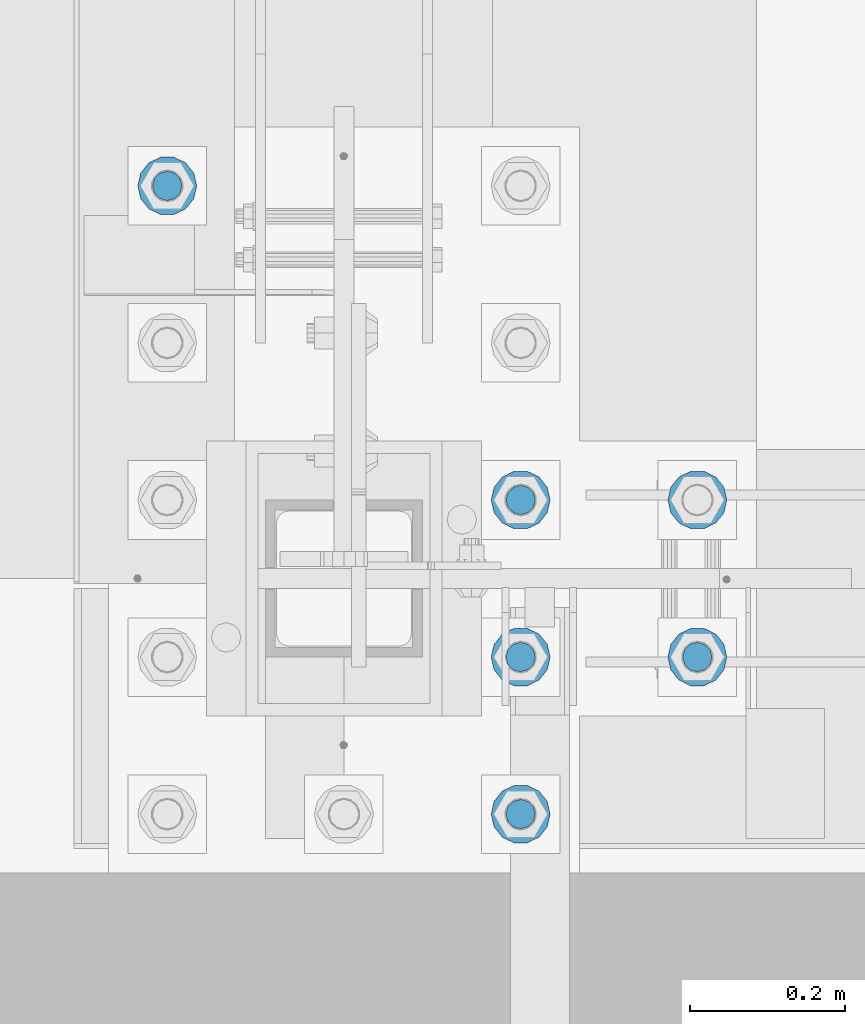
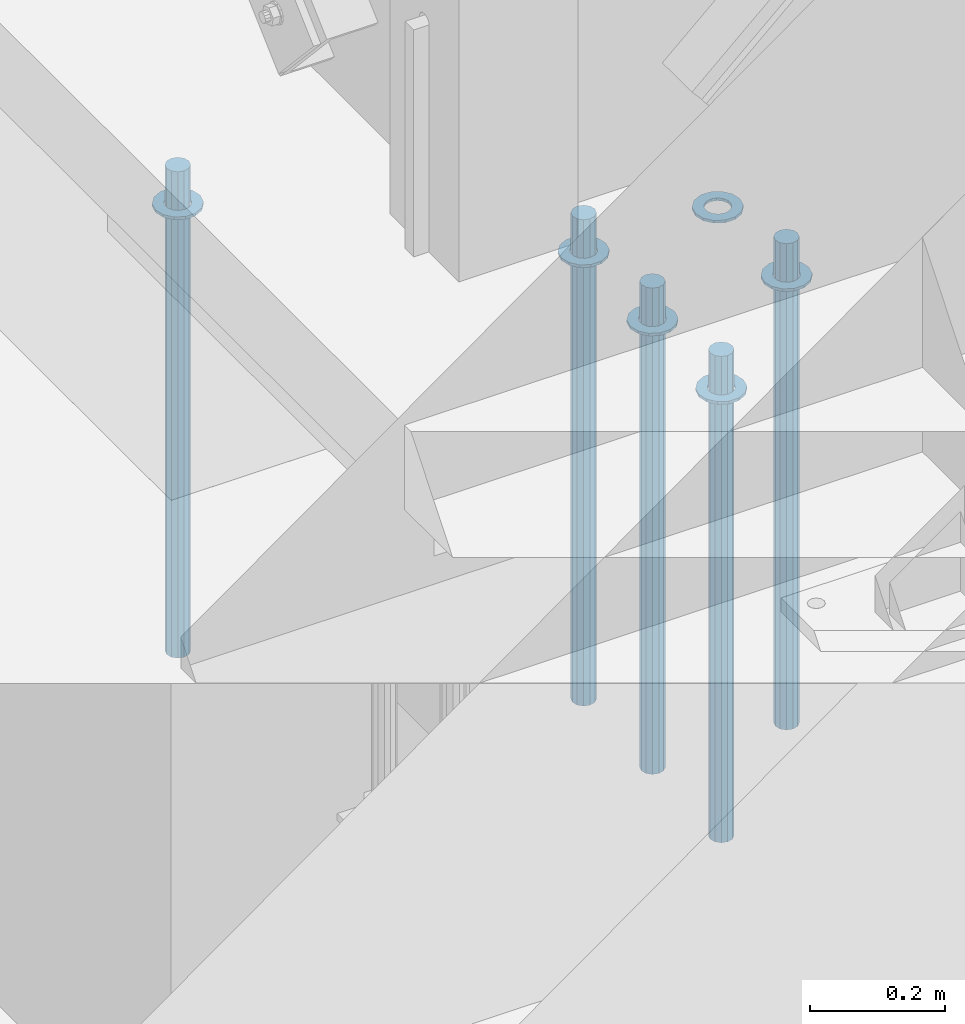
# One storey, part 919 of 1763: 11 columns, 1 element without a shape of its own.
"""IFC2X3 building model written with IfcOpenShell, lengths in millimetres."""

import ifcopenshell
import ifcopenshell.guid

model = None  # the IFC model being written
_history = None  # IfcOwnerHistory: only IFC2X3 demands one
_inside = {}  # id of a spatial element -> (the spatial element, [elements in it])
_under = {}  # id of a project, library or spatial element -> (it, [spatial elements below it])
_declared = {}  # id of a project -> (the project, [libraries it declares])
_typed = {}  # id of a type object -> (the type object, [elements of that type])
_made_of = {}  # id of a material, layer set ... -> (it, [elements and type objects made of it])


def new_model(schema):
    """Start an empty IFC model of exactly this schema.

    Asked for "IFC4X3", IfcOpenShell would pick the latest addendum, in which some entities
    have other attributes; the version numbers below select the first issue.
    IFC2X3 requires an IfcOwnerHistory on every rooted entity: one is made here for all.
    """
    global model, _history
    if schema == "IFC4X3":
        model = ifcopenshell.file(schema_version=(4, 3, 0, 0))
    else:
        model = ifcopenshell.file(schema=schema)
    _inside.clear()
    _under.clear()
    _declared.clear()
    _typed.clear()
    _made_of.clear()
    _history = None
    if model.schema == "IFC2X3":
        org = make("IfcOrganization", Name="unknown")
        user = make(
            "IfcPersonAndOrganization",
            ThePerson=make("IfcPerson", FamilyName="unknown"),
            TheOrganization=org,
        )
        app = make(
            "IfcApplication",
            ApplicationDeveloper=org,
            Version="unknown",
            ApplicationFullName="unknown",
            ApplicationIdentifier="unknown",
        )
        _history = make(
            "IfcOwnerHistory",
            OwningUser=user,
            OwningApplication=app,
            ChangeAction="ADDED",
            CreationDate=0,
        )
    return model


def make(cls, **values):
    """One entity of the class cls with the attributes given. An attribute that is None is left unset."""
    return model.create_entity(
        cls, **{name: value for name, value in values.items() if value is not None}
    )


def rooted(cls, **values):
    """An entity with a GlobalId (a new one), such as an element, a storey or a relation."""
    return make(cls, GlobalId=ifcopenshell.guid.new(), OwnerHistory=_history, **values)


def si_unit(unit_type, name, prefix=None):
    """IfcSIUnit, for example si_unit("LENGTHUNIT", "METRE", prefix="MILLI")."""
    return make("IfcSIUnit", UnitType=unit_type, Prefix=prefix, Name=name)


def assignment(units):
    """IfcUnitAssignment: the units of a project."""
    return None if units is None else make("IfcUnitAssignment", Units=units)


def point(xyz):
    """IfcCartesianPoint."""
    return None if xyz is None else make("IfcCartesianPoint", Coordinates=xyz)


def direction(xyz):
    """IfcDirection."""
    return None if xyz is None else make("IfcDirection", DirectionRatios=xyz)


def frame(location, z_axis=None, x_axis=None):
    """IfcAxis2Placement3D, a coordinate frame: its origin and axes. An axis left out is left unset."""
    return make(
        "IfcAxis2Placement3D",
        Location=point(location),
        Axis=direction(z_axis),
        RefDirection=direction(x_axis),
    )


def origin_with_axes():
    """The frame at (0, 0, 0) with the z axis (0, 0, 1) and the x axis (1, 0, 0) written out."""
    return frame((0.0, 0.0, 0.0), z_axis=(0.0, 0.0, 1.0), x_axis=(1.0, 0.0, 0.0))


def place(relative_to, where):
    """IfcLocalPlacement: puts the frame where relative to a parent placement (None: the world)."""
    return make(
        "IfcLocalPlacement", PlacementRelTo=relative_to, RelativePlacement=where
    )


def context(
    kind, dimensions, precision=None, world=None, true_north=None, identifier=None
):
    """IfcGeometricRepresentationContext, for example the 3D "Model" context."""
    return make(
        "IfcGeometricRepresentationContext",
        ContextIdentifier=identifier,
        ContextType=kind,
        CoordinateSpaceDimension=dimensions,
        Precision=precision,
        WorldCoordinateSystem=world,
        TrueNorth=true_north,
    )


def subcontext(parent, identifier, kind, view, scale=None):
    """IfcGeometricRepresentationSubContext, for example "Body" below "Model"."""
    return make(
        "IfcGeometricRepresentationSubContext",
        ContextIdentifier=identifier,
        ContextType=kind,
        ParentContext=parent,
        TargetScale=scale,
        TargetView=view,
    )


def project(units=None, contexts=None):
    """IfcProject with its units and contexts."""
    return rooted(
        "IfcProject",
        Name="project",
        RepresentationContexts=contexts,
        UnitsInContext=assignment(units),
    )


def spatial(cls, under=None, at=None, **own):
    """A site, building, storey or space (cls), placed at a placement, below another one or the project."""
    s = rooted(cls, ObjectPlacement=at, **own)
    if under is not None:
        _under.setdefault(under.id(), (under, []))[1].append(s)
    return s


def faces_of(points, faces, orient=None, outer=None):
    """IfcFace entities. A face is a list of loops; a loop is a list of indices into points, from 0.

    orient and outer hold one flag for each loop. By default every Orientation is true, the
    first loop of a face is its IfcFaceOuterBound and the others are IfcFaceBound.
    """
    made = []
    for i, loops in enumerate(faces):
        bounds = []
        for j, loop in enumerate(loops):
            is_outer = j == 0 if outer is None else outer[i][j]
            bounds.append(
                make(
                    "IfcFaceOuterBound" if is_outer else "IfcFaceBound",
                    Bound=make("IfcPolyLoop", Polygon=[points[k] for k in loop]),
                    Orientation=True if orient is None else orient[i][j],
                )
            )
        made.append(make("IfcFace", Bounds=bounds))
    return made


def faceted_brep(points, faces, orient=None, outer=None, voids=None):
    """IfcFacetedBrep: a solid bounded by flat faces; with voids (closed shells), ...WithVoids."""
    shared = [point(p) for p in points]
    hull = make("IfcClosedShell", CfsFaces=faces_of(shared, faces, orient, outer))
    if voids is None:
        return make("IfcFacetedBrep", Outer=hull)
    return make(
        "IfcFacetedBrepWithVoids",
        Outer=hull,
        Voids=[
            make(cls, CfsFaces=faces_of(shared, fs, o, b)) for cls, fs, o, b in voids
        ],
    )


def shape(context_of_items, identifier, shape_type, items):
    """IfcShapeRepresentation: the items that make up one representation, for example the "Body"."""
    return make(
        "IfcShapeRepresentation",
        ContextOfItems=context_of_items,
        RepresentationIdentifier=identifier,
        RepresentationType=shape_type,
        Items=items,
    )


def material(Name=None, Category=None):
    """IfcMaterial."""
    return make("IfcMaterial", Name=Name, Category=Category)


def made_of(thing, what):
    """Note that an element or type object is made of a material, layer set ...; save() writes the relation."""
    if what is not None:
        _made_of.setdefault(what.id(), (what, []))[1].append(thing)
    return thing


def type_object(cls, material=None, **own):
    """A type object (cls), such as IfcWallType, which elements share."""
    return made_of(rooted(cls, **own), material)


def element(
    cls,
    number,
    at=None,
    inside=None,
    cuts=None,
    type_object=None,
    material=None,
    context=None,
    identifier="Body",
    shape_type=None,
    held_by="IfcProductDefinitionShape",
    body=None,
    shapes=None,
    **own,
):
    """One element of the class cls, such as IfcWall. Its Tag is "e" and its number.

    at: its placement. inside: the storey or other place that contains it. cuts: it is an
    opening in that element (IfcRelVoidsElement). A single representation is given by context,
    identifier, shape_type and body (its items); several are given by shapes. held_by: the class
    of the entity that holds the representations. save() writes the other relations.
    """
    e = rooted(cls, Tag="e%d" % number, ObjectPlacement=at, **own)
    if body is not None:
        shapes = [shape(context, identifier, shape_type, body)]
    if shapes is not None:
        e.Representation = make(held_by, Representations=shapes)
    if inside is not None:
        _inside.setdefault(inside.id(), (inside, []))[1].append(e)
    if cuts is not None:
        rooted(
            "IfcRelVoidsElement", RelatingBuildingElement=cuts, RelatedOpeningElement=e
        )
    if type_object is not None:
        _typed.setdefault(type_object.id(), (type_object, []))[1].append(e)
    return made_of(e, material)


def aggregate(whole, parts):
    """IfcRelAggregates: a whole, such as a stair, and the parts it consists of."""
    return rooted("IfcRelAggregates", RelatingObject=whole, RelatedObjects=parts)


def save(model, path):
    """Write the relations noted so far, then the file.

    IfcRelAggregates (storeys below a building ...), IfcRelContainedInSpatialStructure (elements
    in a storey), IfcRelDefinesByType, IfcRelAssociatesMaterial and IfcRelDeclares: one each for
    every whole, place, type object, material and project.
    """
    for whole, parts in _under.values():
        aggregate(whole, parts)
    for where, things in _inside.values():
        rooted(
            "IfcRelContainedInSpatialStructure",
            RelatedElements=things,
            RelatingStructure=where,
        )
    for kind, things in _typed.values():
        rooted("IfcRelDefinesByType", RelatedObjects=things, RelatingType=kind)
    for what, things in _made_of.values():
        rooted("IfcRelAssociatesMaterial", RelatedObjects=things, RelatingMaterial=what)
    for by, libraries in _declared.values():
        rooted("IfcRelDeclares", RelatingContext=by, RelatedDefinitions=libraries)
    model.write(path)


model = new_model("IFC2X3")

# Units and contexts
model_context = context("Model", 3, precision=1e-05, world=origin_with_axes())
body_context = subcontext(model_context, "Body", "Model", "MODEL_VIEW")
ifc_project = project(units=[si_unit("LENGTHUNIT", "METRE", prefix="MILLI"), si_unit("AREAUNIT", "SQUARE_METRE"), si_unit("VOLUMEUNIT", "CUBIC_METRE"), si_unit("MASSUNIT", "GRAM", prefix="KILO"), si_unit("TIMEUNIT", "SECOND"), si_unit("PLANEANGLEUNIT", "RADIAN"), si_unit("SOLIDANGLEUNIT", "STERADIAN"), si_unit("THERMODYNAMICTEMPERATUREUNIT", "DEGREE_CELSIUS"), si_unit("LUMINOUSINTENSITYUNIT", "LUMEN")], contexts=[model_context])

# Site, building, storey
site_placement = place(None, origin_with_axes())
site = spatial("IfcSite", under=ifc_project, at=site_placement, CompositionType="ELEMENT")
building_placement = place(site_placement, origin_with_axes())
building = spatial("IfcBuilding", under=site, at=building_placement, Name="Undefined", CompositionType="ELEMENT")
storey_placement = place(building_placement, origin_with_axes())
storey = spatial("IfcBuildingStorey", under=building, at=storey_placement, Name="Undefined", CompositionType="ELEMENT", Elevation=0.0)

# Assembly, columns
assembly_placement = place(storey_placement, origin_with_axes())
assembly = element("IfcElementAssembly", 1, at=assembly_placement, inside=storey, Name="TEMPLATE", AssemblyPlace="NOTDEFINED", PredefinedType="RIGID_FRAME")
ifc_material_1 = material(Name="STEEL/F436")
column_type_1 = type_object("IfcColumnType", Name="1-1/2_WASHER", PredefinedType="NOTDEFINED")
column_1_placement = place(assembly_placement, frame((-87146.8372736983, -14020.8, 5151.43750000001), z_axis=(0.0, 1.0, 0.0), x_axis=(0.0, 0.0, -1.0)))
column_1 = element("IfcColumn", 2, at=column_1_placement, type_object=column_type_1, material=ifc_material_1, Name="WASHER", ObjectType="1-1/2_WASHER", context=body_context, shape_type="Brep", body=[
    faceted_brep([(0.0, -38.0999984741211, 0.0), (0.0, -34.3269124923099, -16.5309697983248), (4.76249999999982, -34.3269124923099, -16.5309697983248), (4.76249999999982, -38.0999984741211, 0.0), (0.0, -23.7549604994492, -29.7877782890519), (4.76249999999982, -23.7549604994492, -29.7877782890519), (0.0, -8.47804724419257, -37.1447519665053), (4.76249999999982, -8.47804724419257, -37.1447519665053), (0.0, 8.47804724419257, -37.1447519665053), (4.76249999999982, 8.47804724419257, -37.1447519665053), (0.0, 23.7549604994492, -29.7877782890519), (4.76249999999982, 23.7549604994492, -29.7877782890519), (0.0, 34.3269124923099, -16.5309697983248), (4.76249999999982, 34.3269124923099, -16.5309697983248), (0.0, 38.0999984741211, 0.0), (4.76249999999982, 38.0999984741211, 0.0), (0.0, 34.3269124923099, 16.5309697983248), (4.76249999999982, 34.3269124923099, 16.5309697983248), (0.0, 23.7549604994492, 29.7877782890519), (4.76249999999982, 23.7549604994492, 29.7877782890519), (0.0, 8.47804724419257, 37.1447519665053), (4.76249999999982, 8.47804724419257, 37.1447519665053), (0.0, -8.47804724419257, 37.1447519665053), (4.76249999999982, -8.47804724419257, 37.1447519665053), (0.0, -23.7549604994492, 29.7877782890519), (4.76249999999982, -23.7549604994492, 29.7877782890519), (0.0, -34.3269124923099, 16.5309697983248), (4.76249999999982, -34.3269124923099, 16.5309697983248), (0.0, 0.0, 20.6399993896484), (0.0, 8.95536011056538, 18.5959968835978), (4.76249999999982, 8.95536011056538, 18.5959968835978), (4.76249999999982, 0.0, 20.6399993896484), (0.0, 16.1370013209453, 12.8688291298167), (4.76249999999982, 16.1370013209453, 12.8688291298167), (0.0, 20.1225115123816, 4.59283194104137), (4.76249999999982, 20.1225115123816, 4.59283194104137), (0.0, 20.1225115123816, -4.59283194104319), (4.76249999999982, 20.1225115123816, -4.59283194104319), (0.0, 16.1370013209453, -12.8688291298167), (4.76249999999982, 16.1370013209453, -12.8688291298167), (0.0, 8.95536011056538, -18.5959968835978), (4.76249999999982, 8.95536011056538, -18.5959968835978), (0.0, 0.0, -20.6399993896484), (4.76249999999982, 0.0, -20.6399993896484), (0.0, -8.95536011056538, -18.5959968835978), (4.76249999999982, -8.95536011056538, -18.5959968835978), (0.0, -16.1370013209453, -12.8688291298167), (4.76249999999982, -16.1370013209453, -12.8688291298167), (0.0, -20.1225115123816, -4.59283194104137), (4.76249999999982, -20.1225115123816, -4.59283194104137), (0.0, -20.1225115123816, 4.59283194104319), (4.76249999999982, -20.1225115123816, 4.59283194104319), (0.0, -16.1370013209453, 12.8688291298167), (4.76249999999982, -16.1370013209453, 12.8688291298167), (0.0, -8.95536011056538, 18.5959968835978), (4.76249999999982, -8.95536011056538, 18.5959968835978)], [[[0, 1, 2, 3]], [[1, 4, 5, 2]], [[4, 6, 7, 5]], [[6, 8, 9, 7]], [[8, 10, 11, 9]], [[10, 12, 13, 11]], [[12, 14, 15, 13]], [[14, 16, 17, 15]], [[16, 18, 19, 17]], [[18, 20, 21, 19]], [[20, 22, 23, 21]], [[22, 24, 25, 23]], [[24, 26, 27, 25]], [[26, 0, 3, 27]], [[28, 29, 30, 31]], [[29, 32, 33, 30]], [[32, 34, 35, 33]], [[34, 36, 37, 35]], [[36, 38, 39, 37]], [[38, 40, 41, 39]], [[40, 42, 43, 41]], [[42, 44, 45, 43]], [[44, 46, 47, 45]], [[46, 48, 49, 47]], [[48, 50, 51, 49]], [[50, 52, 53, 51]], [[52, 54, 55, 53]], [[54, 28, 31, 55]], [[5, 7, 9, 11, 13, 15, 17, 19, 21, 23, 25, 27, 3, 2], [33, 35, 37, 39, 41, 43, 45, 47, 49, 51, 53, 55, 31, 30]], [[26, 24, 22, 20, 18, 16, 14, 12, 10, 8, 6, 4, 1, 0], [54, 52, 50, 48, 46, 44, 42, 40, 38, 36, 34, 32, 29, 28]]]),
])
column_2_placement = place(assembly_placement, frame((-87146.8372736983, -13817.6, 5151.43750000001), z_axis=(0.0, 1.0, 0.0), x_axis=(0.0, 0.0, -1.0)))
column_2 = element("IfcColumn", 3, at=column_2_placement, type_object=column_type_1, material=ifc_material_1, Name="WASHER", ObjectType="1-1/2_WASHER", context=body_context, shape_type="Brep", body=[
    faceted_brep([(0.0, -38.0999984741211, 0.0), (0.0, -34.3269124923099, -16.5309697983248), (4.76249999999982, -34.3269124923099, -16.5309697983248), (4.76249999999982, -38.0999984741211, 0.0), (0.0, -23.7549604994492, -29.7877782890519), (4.76249999999982, -23.7549604994492, -29.7877782890519), (0.0, -8.47804724419257, -37.1447519665053), (4.76249999999982, -8.47804724419257, -37.1447519665053), (0.0, 8.47804724419257, -37.1447519665053), (4.76249999999982, 8.47804724419257, -37.1447519665053), (0.0, 23.7549604994492, -29.7877782890519), (4.76249999999982, 23.7549604994492, -29.7877782890519), (0.0, 34.3269124923099, -16.5309697983248), (4.76249999999982, 34.3269124923099, -16.5309697983248), (0.0, 38.0999984741211, 0.0), (4.76249999999982, 38.0999984741211, 0.0), (0.0, 34.3269124923099, 16.5309697983248), (4.76249999999982, 34.3269124923099, 16.5309697983248), (0.0, 23.7549604994492, 29.7877782890519), (4.76249999999982, 23.7549604994492, 29.7877782890519), (0.0, 8.47804724419257, 37.1447519665053), (4.76249999999982, 8.47804724419257, 37.1447519665053), (0.0, -8.47804724419257, 37.1447519665053), (4.76249999999982, -8.47804724419257, 37.1447519665053), (0.0, -23.7549604994492, 29.7877782890519), (4.76249999999982, -23.7549604994492, 29.7877782890519), (0.0, -34.3269124923099, 16.5309697983248), (4.76249999999982, -34.3269124923099, 16.5309697983248), (0.0, 0.0, 20.6399993896484), (0.0, 8.95536011056538, 18.5959968835978), (4.76249999999982, 8.95536011056538, 18.5959968835978), (4.76249999999982, 0.0, 20.6399993896484), (0.0, 16.1370013209453, 12.8688291298167), (4.76249999999982, 16.1370013209453, 12.8688291298167), (0.0, 20.1225115123816, 4.59283194104137), (4.76249999999982, 20.1225115123816, 4.59283194104137), (0.0, 20.1225115123816, -4.59283194104319), (4.76249999999982, 20.1225115123816, -4.59283194104319), (0.0, 16.1370013209453, -12.8688291298167), (4.76249999999982, 16.1370013209453, -12.8688291298167), (0.0, 8.95536011056538, -18.5959968835978), (4.76249999999982, 8.95536011056538, -18.5959968835978), (0.0, 0.0, -20.6399993896484), (4.76249999999982, 0.0, -20.6399993896484), (0.0, -8.95536011056538, -18.5959968835978), (4.76249999999982, -8.95536011056538, -18.5959968835978), (0.0, -16.1370013209453, -12.8688291298167), (4.76249999999982, -16.1370013209453, -12.8688291298167), (0.0, -20.1225115123816, -4.59283194104137), (4.76249999999982, -20.1225115123816, -4.59283194104137), (0.0, -20.1225115123816, 4.59283194104319), (4.76249999999982, -20.1225115123816, 4.59283194104319), (0.0, -16.1370013209453, 12.8688291298167), (4.76249999999982, -16.1370013209453, 12.8688291298167), (0.0, -8.95536011056538, 18.5959968835978), (4.76249999999982, -8.95536011056538, 18.5959968835978)], [[[0, 1, 2, 3]], [[1, 4, 5, 2]], [[4, 6, 7, 5]], [[6, 8, 9, 7]], [[8, 10, 11, 9]], [[10, 12, 13, 11]], [[12, 14, 15, 13]], [[14, 16, 17, 15]], [[16, 18, 19, 17]], [[18, 20, 21, 19]], [[20, 22, 23, 21]], [[22, 24, 25, 23]], [[24, 26, 27, 25]], [[26, 0, 3, 27]], [[28, 29, 30, 31]], [[29, 32, 33, 30]], [[32, 34, 35, 33]], [[34, 36, 37, 35]], [[36, 38, 39, 37]], [[38, 40, 41, 39]], [[40, 42, 43, 41]], [[42, 44, 45, 43]], [[44, 46, 47, 45]], [[46, 48, 49, 47]], [[48, 50, 51, 49]], [[50, 52, 53, 51]], [[52, 54, 55, 53]], [[54, 28, 31, 55]], [[5, 7, 9, 11, 13, 15, 17, 19, 21, 23, 25, 27, 3, 2], [33, 35, 37, 39, 41, 43, 45, 47, 49, 51, 53, 55, 31, 30]], [[26, 24, 22, 20, 18, 16, 14, 12, 10, 8, 6, 4, 1, 0], [54, 52, 50, 48, 46, 44, 42, 40, 38, 36, 34, 32, 29, 28]]]),
])
column_3_placement = place(assembly_placement, frame((-86918.2372736983, -13817.6, 5151.43750000001), z_axis=(0.0, 1.0, 0.0), x_axis=(0.0, 0.0, -1.0)))
column_3 = element("IfcColumn", 4, at=column_3_placement, type_object=column_type_1, material=ifc_material_1, Name="WASHER", ObjectType="1-1/2_WASHER", context=body_context, shape_type="Brep", body=[
    faceted_brep([(0.0, -38.0999984741211, 0.0), (0.0, -34.3269124923099, -16.5309697983248), (4.76249999999982, -34.3269124923099, -16.5309697983248), (4.76249999999982, -38.0999984741211, 0.0), (0.0, -23.7549604994492, -29.7877782890519), (4.76249999999982, -23.7549604994492, -29.7877782890519), (0.0, -8.47804724419257, -37.1447519665053), (4.76249999999982, -8.47804724419257, -37.1447519665053), (0.0, 8.47804724419257, -37.1447519665053), (4.76249999999982, 8.47804724419257, -37.1447519665053), (0.0, 23.7549604994492, -29.7877782890519), (4.76249999999982, 23.7549604994492, -29.7877782890519), (0.0, 34.3269124923099, -16.5309697983248), (4.76249999999982, 34.3269124923099, -16.5309697983248), (0.0, 38.0999984741211, 0.0), (4.76249999999982, 38.0999984741211, 0.0), (0.0, 34.3269124923099, 16.5309697983248), (4.76249999999982, 34.3269124923099, 16.5309697983248), (0.0, 23.7549604994492, 29.7877782890519), (4.76249999999982, 23.7549604994492, 29.7877782890519), (0.0, 8.47804724419257, 37.1447519665053), (4.76249999999982, 8.47804724419257, 37.1447519665053), (0.0, -8.47804724419257, 37.1447519665053), (4.76249999999982, -8.47804724419257, 37.1447519665053), (0.0, -23.7549604994492, 29.7877782890519), (4.76249999999982, -23.7549604994492, 29.7877782890519), (0.0, -34.3269124923099, 16.5309697983248), (4.76249999999982, -34.3269124923099, 16.5309697983248), (0.0, 0.0, 20.6399993896484), (0.0, 8.95536011056538, 18.5959968835978), (4.76249999999982, 8.95536011056538, 18.5959968835978), (4.76249999999982, 0.0, 20.6399993896484), (0.0, 16.1370013209453, 12.8688291298167), (4.76249999999982, 16.1370013209453, 12.8688291298167), (0.0, 20.1225115123816, 4.59283194104137), (4.76249999999982, 20.1225115123816, 4.59283194104137), (0.0, 20.1225115123816, -4.59283194104319), (4.76249999999982, 20.1225115123816, -4.59283194104319), (0.0, 16.1370013209453, -12.8688291298167), (4.76249999999982, 16.1370013209453, -12.8688291298167), (0.0, 8.95536011056538, -18.5959968835978), (4.76249999999982, 8.95536011056538, -18.5959968835978), (0.0, 0.0, -20.6399993896484), (4.76249999999982, 0.0, -20.6399993896484), (0.0, -8.95536011056538, -18.5959968835978), (4.76249999999982, -8.95536011056538, -18.5959968835978), (0.0, -16.1370013209453, -12.8688291298167), (4.76249999999982, -16.1370013209453, -12.8688291298167), (0.0, -20.1225115123816, -4.59283194104137), (4.76249999999982, -20.1225115123816, -4.59283194104137), (0.0, -20.1225115123816, 4.59283194104319), (4.76249999999982, -20.1225115123816, 4.59283194104319), (0.0, -16.1370013209453, 12.8688291298167), (4.76249999999982, -16.1370013209453, 12.8688291298167), (0.0, -8.95536011056538, 18.5959968835978), (4.76249999999982, -8.95536011056538, 18.5959968835978)], [[[0, 1, 2, 3]], [[1, 4, 5, 2]], [[4, 6, 7, 5]], [[6, 8, 9, 7]], [[8, 10, 11, 9]], [[10, 12, 13, 11]], [[12, 14, 15, 13]], [[14, 16, 17, 15]], [[16, 18, 19, 17]], [[18, 20, 21, 19]], [[20, 22, 23, 21]], [[22, 24, 25, 23]], [[24, 26, 27, 25]], [[26, 0, 3, 27]], [[28, 29, 30, 31]], [[29, 32, 33, 30]], [[32, 34, 35, 33]], [[34, 36, 37, 35]], [[36, 38, 39, 37]], [[38, 40, 41, 39]], [[40, 42, 43, 41]], [[42, 44, 45, 43]], [[44, 46, 47, 45]], [[46, 48, 49, 47]], [[48, 50, 51, 49]], [[50, 52, 53, 51]], [[52, 54, 55, 53]], [[54, 28, 31, 55]], [[5, 7, 9, 11, 13, 15, 17, 19, 21, 23, 25, 27, 3, 2], [33, 35, 37, 39, 41, 43, 45, 47, 49, 51, 53, 55, 31, 30]], [[26, 24, 22, 20, 18, 16, 14, 12, 10, 8, 6, 4, 1, 0], [54, 52, 50, 48, 46, 44, 42, 40, 38, 36, 34, 32, 29, 28]]]),
])
column_4_placement = place(assembly_placement, frame((-87146.8372736983, -13614.4, 5151.43750000001), z_axis=(0.0, 1.0, 0.0), x_axis=(0.0, 0.0, -1.0)))
column_4 = element("IfcColumn", 5, at=column_4_placement, type_object=column_type_1, material=ifc_material_1, Name="WASHER", ObjectType="1-1/2_WASHER", context=body_context, shape_type="Brep", body=[
    faceted_brep([(0.0, -38.0999984741211, 0.0), (0.0, -34.3269124923099, -16.5309697983248), (4.76249999999982, -34.3269124923099, -16.5309697983248), (4.76249999999982, -38.0999984741211, 0.0), (0.0, -23.7549604994492, -29.7877782890519), (4.76249999999982, -23.7549604994492, -29.7877782890519), (0.0, -8.47804724419257, -37.1447519665053), (4.76249999999982, -8.47804724419257, -37.1447519665053), (0.0, 8.47804724419257, -37.1447519665053), (4.76249999999982, 8.47804724419257, -37.1447519665053), (0.0, 23.7549604994492, -29.7877782890519), (4.76249999999982, 23.7549604994492, -29.7877782890519), (0.0, 34.3269124923099, -16.5309697983248), (4.76249999999982, 34.3269124923099, -16.5309697983248), (0.0, 38.0999984741211, 0.0), (4.76249999999982, 38.0999984741211, 0.0), (0.0, 34.3269124923099, 16.5309697983248), (4.76249999999982, 34.3269124923099, 16.5309697983248), (0.0, 23.7549604994492, 29.7877782890519), (4.76249999999982, 23.7549604994492, 29.7877782890519), (0.0, 8.47804724419257, 37.1447519665053), (4.76249999999982, 8.47804724419257, 37.1447519665053), (0.0, -8.47804724419257, 37.1447519665053), (4.76249999999982, -8.47804724419257, 37.1447519665053), (0.0, -23.7549604994492, 29.7877782890519), (4.76249999999982, -23.7549604994492, 29.7877782890519), (0.0, -34.3269124923099, 16.5309697983248), (4.76249999999982, -34.3269124923099, 16.5309697983248), (0.0, 0.0, 20.6399993896484), (0.0, 8.95536011056538, 18.5959968835978), (4.76249999999982, 8.95536011056538, 18.5959968835978), (4.76249999999982, 0.0, 20.6399993896484), (0.0, 16.1370013209453, 12.8688291298167), (4.76249999999982, 16.1370013209453, 12.8688291298167), (0.0, 20.1225115123816, 4.59283194104137), (4.76249999999982, 20.1225115123816, 4.59283194104137), (0.0, 20.1225115123816, -4.59283194104319), (4.76249999999982, 20.1225115123816, -4.59283194104319), (0.0, 16.1370013209453, -12.8688291298167), (4.76249999999982, 16.1370013209453, -12.8688291298167), (0.0, 8.95536011056538, -18.5959968835978), (4.76249999999982, 8.95536011056538, -18.5959968835978), (0.0, 0.0, -20.6399993896484), (4.76249999999982, 0.0, -20.6399993896484), (0.0, -8.95536011056538, -18.5959968835978), (4.76249999999982, -8.95536011056538, -18.5959968835978), (0.0, -16.1370013209453, -12.8688291298167), (4.76249999999982, -16.1370013209453, -12.8688291298167), (0.0, -20.1225115123816, -4.59283194104137), (4.76249999999982, -20.1225115123816, -4.59283194104137), (0.0, -20.1225115123816, 4.59283194104319), (4.76249999999982, -20.1225115123816, 4.59283194104319), (0.0, -16.1370013209453, 12.8688291298167), (4.76249999999982, -16.1370013209453, 12.8688291298167), (0.0, -8.95536011056538, 18.5959968835978), (4.76249999999982, -8.95536011056538, 18.5959968835978)], [[[0, 1, 2, 3]], [[1, 4, 5, 2]], [[4, 6, 7, 5]], [[6, 8, 9, 7]], [[8, 10, 11, 9]], [[10, 12, 13, 11]], [[12, 14, 15, 13]], [[14, 16, 17, 15]], [[16, 18, 19, 17]], [[18, 20, 21, 19]], [[20, 22, 23, 21]], [[22, 24, 25, 23]], [[24, 26, 27, 25]], [[26, 0, 3, 27]], [[28, 29, 30, 31]], [[29, 32, 33, 30]], [[32, 34, 35, 33]], [[34, 36, 37, 35]], [[36, 38, 39, 37]], [[38, 40, 41, 39]], [[40, 42, 43, 41]], [[42, 44, 45, 43]], [[44, 46, 47, 45]], [[46, 48, 49, 47]], [[48, 50, 51, 49]], [[50, 52, 53, 51]], [[52, 54, 55, 53]], [[54, 28, 31, 55]], [[5, 7, 9, 11, 13, 15, 17, 19, 21, 23, 25, 27, 3, 2], [33, 35, 37, 39, 41, 43, 45, 47, 49, 51, 53, 55, 31, 30]], [[26, 24, 22, 20, 18, 16, 14, 12, 10, 8, 6, 4, 1, 0], [54, 52, 50, 48, 46, 44, 42, 40, 38, 36, 34, 32, 29, 28]]]),
])
column_5_placement = place(assembly_placement, frame((-86918.2372736983, -13614.4, 5151.43750000001), z_axis=(0.0, 1.0, 0.0), x_axis=(0.0, 0.0, -1.0)))
column_5 = element("IfcColumn", 6, at=column_5_placement, type_object=column_type_1, material=ifc_material_1, Name="WASHER", ObjectType="1-1/2_WASHER", context=body_context, shape_type="Brep", body=[
    faceted_brep([(0.0, -38.0999984741211, 0.0), (0.0, -34.3269124923099, -16.5309697983248), (4.76249999999982, -34.3269124923099, -16.5309697983248), (4.76249999999982, -38.0999984741211, 0.0), (0.0, -23.7549604994492, -29.7877782890519), (4.76249999999982, -23.7549604994492, -29.7877782890519), (0.0, -8.47804724419257, -37.1447519665053), (4.76249999999982, -8.47804724419257, -37.1447519665053), (0.0, 8.47804724419257, -37.1447519665053), (4.76249999999982, 8.47804724419257, -37.1447519665053), (0.0, 23.7549604994492, -29.7877782890519), (4.76249999999982, 23.7549604994492, -29.7877782890519), (0.0, 34.3269124923099, -16.5309697983248), (4.76249999999982, 34.3269124923099, -16.5309697983248), (0.0, 38.0999984741211, 0.0), (4.76249999999982, 38.0999984741211, 0.0), (0.0, 34.3269124923099, 16.5309697983248), (4.76249999999982, 34.3269124923099, 16.5309697983248), (0.0, 23.7549604994492, 29.7877782890519), (4.76249999999982, 23.7549604994492, 29.7877782890519), (0.0, 8.47804724419257, 37.1447519665053), (4.76249999999982, 8.47804724419257, 37.1447519665053), (0.0, -8.47804724419257, 37.1447519665053), (4.76249999999982, -8.47804724419257, 37.1447519665053), (0.0, -23.7549604994492, 29.7877782890519), (4.76249999999982, -23.7549604994492, 29.7877782890519), (0.0, -34.3269124923099, 16.5309697983248), (4.76249999999982, -34.3269124923099, 16.5309697983248), (0.0, 0.0, 20.6399993896484), (0.0, 8.95536011056538, 18.5959968835978), (4.76249999999982, 8.95536011056538, 18.5959968835978), (4.76249999999982, 0.0, 20.6399993896484), (0.0, 16.1370013209453, 12.8688291298167), (4.76249999999982, 16.1370013209453, 12.8688291298167), (0.0, 20.1225115123816, 4.59283194104137), (4.76249999999982, 20.1225115123816, 4.59283194104137), (0.0, 20.1225115123816, -4.59283194104319), (4.76249999999982, 20.1225115123816, -4.59283194104319), (0.0, 16.1370013209453, -12.8688291298167), (4.76249999999982, 16.1370013209453, -12.8688291298167), (0.0, 8.95536011056538, -18.5959968835978), (4.76249999999982, 8.95536011056538, -18.5959968835978), (0.0, 0.0, -20.6399993896484), (4.76249999999982, 0.0, -20.6399993896484), (0.0, -8.95536011056538, -18.5959968835978), (4.76249999999982, -8.95536011056538, -18.5959968835978), (0.0, -16.1370013209453, -12.8688291298167), (4.76249999999982, -16.1370013209453, -12.8688291298167), (0.0, -20.1225115123816, -4.59283194104137), (4.76249999999982, -20.1225115123816, -4.59283194104137), (0.0, -20.1225115123816, 4.59283194104319), (4.76249999999982, -20.1225115123816, 4.59283194104319), (0.0, -16.1370013209453, 12.8688291298167), (4.76249999999982, -16.1370013209453, 12.8688291298167), (0.0, -8.95536011056538, 18.5959968835978), (4.76249999999982, -8.95536011056538, 18.5959968835978)], [[[0, 1, 2, 3]], [[1, 4, 5, 2]], [[4, 6, 7, 5]], [[6, 8, 9, 7]], [[8, 10, 11, 9]], [[10, 12, 13, 11]], [[12, 14, 15, 13]], [[14, 16, 17, 15]], [[16, 18, 19, 17]], [[18, 20, 21, 19]], [[20, 22, 23, 21]], [[22, 24, 25, 23]], [[24, 26, 27, 25]], [[26, 0, 3, 27]], [[28, 29, 30, 31]], [[29, 32, 33, 30]], [[32, 34, 35, 33]], [[34, 36, 37, 35]], [[36, 38, 39, 37]], [[38, 40, 41, 39]], [[40, 42, 43, 41]], [[42, 44, 45, 43]], [[44, 46, 47, 45]], [[46, 48, 49, 47]], [[48, 50, 51, 49]], [[50, 52, 53, 51]], [[52, 54, 55, 53]], [[54, 28, 31, 55]], [[5, 7, 9, 11, 13, 15, 17, 19, 21, 23, 25, 27, 3, 2], [33, 35, 37, 39, 41, 43, 45, 47, 49, 51, 53, 55, 31, 30]], [[26, 24, 22, 20, 18, 16, 14, 12, 10, 8, 6, 4, 1, 0], [54, 52, 50, 48, 46, 44, 42, 40, 38, 36, 34, 32, 29, 28]]]),
])
column_6_placement = place(assembly_placement, frame((-87604.0372736983, -13208.0, 5151.43750000001), z_axis=(0.0, -1.0, 0.0), x_axis=(0.0, 0.0, -1.0)))
column_6 = element("IfcColumn", 7, at=column_6_placement, type_object=column_type_1, material=ifc_material_1, Name="WASHER", ObjectType="1-1/2_WASHER", context=body_context, shape_type="Brep", body=[
    faceted_brep([(0.0, -38.0999984741211, 0.0), (0.0, -34.3269124923099, -16.5309697983248), (4.76249999999982, -34.3269124923099, -16.5309697983248), (4.76249999999982, -38.0999984741211, 0.0), (0.0, -23.7549604994492, -29.7877782890519), (4.76249999999982, -23.7549604994492, -29.7877782890519), (0.0, -8.47804724419257, -37.1447519665053), (4.76249999999982, -8.47804724419257, -37.1447519665053), (0.0, 8.47804724419257, -37.1447519665053), (4.76249999999982, 8.47804724419257, -37.1447519665053), (0.0, 23.7549604994492, -29.7877782890519), (4.76249999999982, 23.7549604994492, -29.7877782890519), (0.0, 34.3269124923099, -16.5309697983248), (4.76249999999982, 34.3269124923099, -16.5309697983248), (0.0, 38.0999984741211, 0.0), (4.76249999999982, 38.0999984741211, 0.0), (0.0, 34.3269124923099, 16.5309697983248), (4.76249999999982, 34.3269124923099, 16.5309697983248), (0.0, 23.7549604994492, 29.7877782890519), (4.76249999999982, 23.7549604994492, 29.7877782890519), (0.0, 8.47804724419257, 37.1447519665053), (4.76249999999982, 8.47804724419257, 37.1447519665053), (0.0, -8.47804724419257, 37.1447519665053), (4.76249999999982, -8.47804724419257, 37.1447519665053), (0.0, -23.7549604994492, 29.7877782890519), (4.76249999999982, -23.7549604994492, 29.7877782890519), (0.0, -34.3269124923099, 16.5309697983248), (4.76249999999982, -34.3269124923099, 16.5309697983248), (0.0, 0.0, 20.6399993896484), (0.0, 8.95536011056538, 18.5959968835978), (4.76249999999982, 8.95536011056538, 18.5959968835978), (4.76249999999982, 0.0, 20.6399993896484), (0.0, 16.1370013209453, 12.8688291298167), (4.76249999999982, 16.1370013209453, 12.8688291298167), (0.0, 20.1225115123816, 4.59283194104137), (4.76249999999982, 20.1225115123816, 4.59283194104137), (0.0, 20.1225115123816, -4.59283194104319), (4.76249999999982, 20.1225115123816, -4.59283194104319), (0.0, 16.1370013209453, -12.8688291298167), (4.76249999999982, 16.1370013209453, -12.8688291298167), (0.0, 8.95536011056538, -18.5959968835978), (4.76249999999982, 8.95536011056538, -18.5959968835978), (0.0, 0.0, -20.6399993896484), (4.76249999999982, 0.0, -20.6399993896484), (0.0, -8.95536011056538, -18.5959968835978), (4.76249999999982, -8.95536011056538, -18.5959968835978), (0.0, -16.1370013209453, -12.8688291298167), (4.76249999999982, -16.1370013209453, -12.8688291298167), (0.0, -20.1225115123816, -4.59283194104137), (4.76249999999982, -20.1225115123816, -4.59283194104137), (0.0, -20.1225115123816, 4.59283194104319), (4.76249999999982, -20.1225115123816, 4.59283194104319), (0.0, -16.1370013209453, 12.8688291298167), (4.76249999999982, -16.1370013209453, 12.8688291298167), (0.0, -8.95536011056538, 18.5959968835978), (4.76249999999982, -8.95536011056538, 18.5959968835978)], [[[0, 1, 2, 3]], [[1, 4, 5, 2]], [[4, 6, 7, 5]], [[6, 8, 9, 7]], [[8, 10, 11, 9]], [[10, 12, 13, 11]], [[12, 14, 15, 13]], [[14, 16, 17, 15]], [[16, 18, 19, 17]], [[18, 20, 21, 19]], [[20, 22, 23, 21]], [[22, 24, 25, 23]], [[24, 26, 27, 25]], [[26, 0, 3, 27]], [[28, 29, 30, 31]], [[29, 32, 33, 30]], [[32, 34, 35, 33]], [[34, 36, 37, 35]], [[36, 38, 39, 37]], [[38, 40, 41, 39]], [[40, 42, 43, 41]], [[42, 44, 45, 43]], [[44, 46, 47, 45]], [[46, 48, 49, 47]], [[48, 50, 51, 49]], [[50, 52, 53, 51]], [[52, 54, 55, 53]], [[54, 28, 31, 55]], [[5, 7, 9, 11, 13, 15, 17, 19, 21, 23, 25, 27, 3, 2], [33, 35, 37, 39, 41, 43, 45, 47, 49, 51, 53, 55, 31, 30]], [[26, 24, 22, 20, 18, 16, 14, 12, 10, 8, 6, 4, 1, 0], [54, 52, 50, 48, 46, 44, 42, 40, 38, 36, 34, 32, 29, 28]]]),
])
ifc_material_2 = material(Name="STEEL/F1554-GR.55")
column_type_2 = type_object("IfcColumnType", PredefinedType="NOTDEFINED")
column_7_placement = place(assembly_placement, frame((-87146.8372736983, -14020.8, 5219.70000000001), z_axis=(0.0, 1.0, 0.0), x_axis=(0.0, 0.0, -1.0)))
column_7 = element("IfcColumn", 8, at=column_7_placement, type_object=column_type_2, material=ifc_material_2, Name="ALL THREADED ROD", context=body_context, shape_type="Brep", body=[
    faceted_brep([(0.0, -19.0500000000029, 0.0), (0.0, -16.4977839420899, -9.52500000000146), (876.299, -16.4977839420899, -9.52499999999964), (876.299, -19.0500000000029, 0.0), (0.0, -9.52499999999418, -16.4977839420935), (876.299, -9.52499999999418, -16.4977839420935), (1.45519152283669e-11, 1.81898940354586e-12, -19.0499999999993), (876.299, 0.0, -19.0500000000002), (0.0, 9.52499999999418, -16.4977839420935), (876.299, 9.52499999999418, -16.4977839420935), (0.0, 16.4977839420899, -9.52500000000146), (876.299, 16.4977839420899, -9.52499999999964), (0.0, 19.0500000000029, 0.0), (876.299, 19.0500000000029, 0.0), (0.0, 16.4977839420899, 9.52500000000146), (876.299, 16.4977839420899, 9.52499999999964), (0.0, 9.52499999999418, 16.4977839420935), (876.299, 9.52499999999418, 16.4977839420935), (1.45519152283669e-11, 1.81898940354586e-12, 19.0499999999993), (876.299, 0.0, 19.0500000000002), (0.0, -9.52499999999418, 16.4977839420935), (876.299, -9.52499999999418, 16.4977839420935), (0.0, -16.4977839420899, 9.52500000000146), (876.299, -16.4977839420899, 9.52499999999964)], [[[0, 1, 2, 3]], [[1, 4, 5, 2]], [[4, 6, 7, 5]], [[6, 8, 9, 7]], [[8, 10, 11, 9]], [[10, 12, 13, 11]], [[12, 14, 15, 13]], [[14, 16, 17, 15]], [[16, 18, 19, 17]], [[18, 20, 21, 19]], [[20, 22, 23, 21]], [[22, 0, 3, 23]], [[5, 7, 9, 11, 13, 15, 17, 19, 21, 23, 3, 2]], [[22, 20, 18, 16, 14, 12, 10, 8, 6, 4, 1, 0]]]),
])
column_8_placement = place(assembly_placement, frame((-87146.8372736983, -13817.6, 5219.70000000001), z_axis=(0.0, 1.0, 0.0), x_axis=(0.0, 0.0, -1.0)))
column_8 = element("IfcColumn", 9, at=column_8_placement, type_object=column_type_2, material=ifc_material_2, Name="ALL THREADED ROD", context=body_context, shape_type="Brep", body=[
    faceted_brep([(0.0, -19.0500000000029, 0.0), (0.0, -16.4977839420899, -9.52500000000146), (876.299, -16.4977839420899, -9.52499999999964), (876.299, -19.0500000000029, 0.0), (0.0, -9.52499999999418, -16.4977839420935), (876.299, -9.52499999999418, -16.4977839420935), (1.45519152283669e-11, 1.81898940354586e-12, -19.0499999999993), (876.299, 0.0, -19.0500000000002), (0.0, 9.52499999999418, -16.4977839420935), (876.299, 9.52499999999418, -16.4977839420935), (0.0, 16.4977839420899, -9.52500000000146), (876.299, 16.4977839420899, -9.52499999999964), (0.0, 19.0500000000029, 0.0), (876.299, 19.0500000000029, 0.0), (0.0, 16.4977839420899, 9.52500000000146), (876.299, 16.4977839420899, 9.52499999999964), (0.0, 9.52499999999418, 16.4977839420935), (876.299, 9.52499999999418, 16.4977839420935), (1.45519152283669e-11, 1.81898940354586e-12, 19.0499999999993), (876.299, 0.0, 19.0500000000002), (0.0, -9.52499999999418, 16.4977839420935), (876.299, -9.52499999999418, 16.4977839420935), (0.0, -16.4977839420899, 9.52500000000146), (876.299, -16.4977839420899, 9.52499999999964)], [[[0, 1, 2, 3]], [[1, 4, 5, 2]], [[4, 6, 7, 5]], [[6, 8, 9, 7]], [[8, 10, 11, 9]], [[10, 12, 13, 11]], [[12, 14, 15, 13]], [[14, 16, 17, 15]], [[16, 18, 19, 17]], [[18, 20, 21, 19]], [[20, 22, 23, 21]], [[22, 0, 3, 23]], [[5, 7, 9, 11, 13, 15, 17, 19, 21, 23, 3, 2]], [[22, 20, 18, 16, 14, 12, 10, 8, 6, 4, 1, 0]]]),
])
column_9_placement = place(assembly_placement, frame((-86918.2372736983, -13817.6, 5219.70000000001), z_axis=(0.0, 1.0, 0.0), x_axis=(0.0, 0.0, -1.0)))
column_9 = element("IfcColumn", 10, at=column_9_placement, type_object=column_type_2, material=ifc_material_2, Name="ALL THREADED ROD", context=body_context, shape_type="Brep", body=[
    faceted_brep([(0.0, -19.0500000000029, 0.0), (0.0, -16.4977839420899, -9.52500000000146), (876.299, -16.4977839420899, -9.52499999999964), (876.299, -19.0500000000029, 0.0), (0.0, -9.52499999999418, -16.4977839420935), (876.299, -9.52499999999418, -16.4977839420935), (1.45519152283669e-11, 1.81898940354586e-12, -19.0499999999993), (876.299, 0.0, -19.0500000000002), (0.0, 9.52499999999418, -16.4977839420935), (876.299, 9.52499999999418, -16.4977839420935), (0.0, 16.4977839420899, -9.52500000000146), (876.299, 16.4977839420899, -9.52499999999964), (0.0, 19.0500000000029, 0.0), (876.299, 19.0500000000029, 0.0), (0.0, 16.4977839420899, 9.52500000000146), (876.299, 16.4977839420899, 9.52499999999964), (0.0, 9.52499999999418, 16.4977839420935), (876.299, 9.52499999999418, 16.4977839420935), (1.45519152283669e-11, 1.81898940354586e-12, 19.0499999999993), (876.299, 0.0, 19.0500000000002), (0.0, -9.52499999999418, 16.4977839420935), (876.299, -9.52499999999418, 16.4977839420935), (0.0, -16.4977839420899, 9.52500000000146), (876.299, -16.4977839420899, 9.52499999999964)], [[[0, 1, 2, 3]], [[1, 4, 5, 2]], [[4, 6, 7, 5]], [[6, 8, 9, 7]], [[8, 10, 11, 9]], [[10, 12, 13, 11]], [[12, 14, 15, 13]], [[14, 16, 17, 15]], [[16, 18, 19, 17]], [[18, 20, 21, 19]], [[20, 22, 23, 21]], [[22, 0, 3, 23]], [[5, 7, 9, 11, 13, 15, 17, 19, 21, 23, 3, 2]], [[22, 20, 18, 16, 14, 12, 10, 8, 6, 4, 1, 0]]]),
])
column_10_placement = place(assembly_placement, frame((-87146.8372736983, -13614.4, 5219.70000000001), z_axis=(0.0, 1.0, 0.0), x_axis=(0.0, 0.0, -1.0)))
column_10 = element("IfcColumn", 11, at=column_10_placement, type_object=column_type_2, material=ifc_material_2, Name="ALL THREADED ROD", context=body_context, shape_type="Brep", body=[
    faceted_brep([(0.0, -19.0500000000029, 0.0), (0.0, -16.4977839420899, -9.52500000000146), (876.299, -16.4977839420899, -9.52499999999964), (876.299, -19.0500000000029, 0.0), (0.0, -9.52499999999418, -16.4977839420935), (876.299, -9.52499999999418, -16.4977839420935), (1.45519152283669e-11, 1.81898940354586e-12, -19.0499999999993), (876.299, 0.0, -19.0500000000002), (0.0, 9.52499999999418, -16.4977839420935), (876.299, 9.52499999999418, -16.4977839420935), (0.0, 16.4977839420899, -9.52500000000146), (876.299, 16.4977839420899, -9.52499999999964), (0.0, 19.0500000000029, 0.0), (876.299, 19.0500000000029, 0.0), (0.0, 16.4977839420899, 9.52500000000146), (876.299, 16.4977839420899, 9.52499999999964), (0.0, 9.52499999999418, 16.4977839420935), (876.299, 9.52499999999418, 16.4977839420935), (1.45519152283669e-11, 1.81898940354586e-12, 19.0499999999993), (876.299, 0.0, 19.0500000000002), (0.0, -9.52499999999418, 16.4977839420935), (876.299, -9.52499999999418, 16.4977839420935), (0.0, -16.4977839420899, 9.52500000000146), (876.299, -16.4977839420899, 9.52499999999964)], [[[0, 1, 2, 3]], [[1, 4, 5, 2]], [[4, 6, 7, 5]], [[6, 8, 9, 7]], [[8, 10, 11, 9]], [[10, 12, 13, 11]], [[12, 14, 15, 13]], [[14, 16, 17, 15]], [[16, 18, 19, 17]], [[18, 20, 21, 19]], [[20, 22, 23, 21]], [[22, 0, 3, 23]], [[5, 7, 9, 11, 13, 15, 17, 19, 21, 23, 3, 2]], [[22, 20, 18, 16, 14, 12, 10, 8, 6, 4, 1, 0]]]),
])
column_11_placement = place(assembly_placement, frame((-87604.0372736983, -13208.0, 5219.70000000001), z_axis=(0.0, -1.0, 0.0), x_axis=(0.0, 0.0, -1.0)))
column_11 = element("IfcColumn", 12, at=column_11_placement, type_object=column_type_2, material=ifc_material_2, Name="ALL THREADED ROD", context=body_context, shape_type="Brep", body=[
    faceted_brep([(0.0, -19.0500000000029, 0.0), (0.0, -16.4977839420899, -9.52500000000146), (876.299, -16.4977839420899, -9.52499999999964), (876.299, -19.0500000000029, 0.0), (0.0, -9.52499999999418, -16.4977839420935), (876.299, -9.52499999999418, -16.4977839420935), (1.45519152283669e-11, 1.81898940354586e-12, -19.0499999999993), (876.299, 0.0, -19.0500000000002), (0.0, 9.52499999999418, -16.4977839420935), (876.299, 9.52499999999418, -16.4977839420935), (0.0, 16.4977839420899, -9.52500000000146), (876.299, 16.4977839420899, -9.52499999999964), (0.0, 19.0500000000029, 0.0), (876.299, 19.0500000000029, 0.0), (0.0, 16.4977839420899, 9.52500000000146), (876.299, 16.4977839420899, 9.52499999999964), (0.0, 9.52499999999418, 16.4977839420935), (876.299, 9.52499999999418, 16.4977839420935), (1.45519152283669e-11, 1.81898940354586e-12, 19.0499999999993), (876.299, 0.0, 19.0500000000002), (0.0, -9.52499999999418, 16.4977839420935), (876.299, -9.52499999999418, 16.4977839420935), (0.0, -16.4977839420899, 9.52500000000146), (876.299, -16.4977839420899, 9.52499999999964)], [[[0, 1, 2, 3]], [[1, 4, 5, 2]], [[4, 6, 7, 5]], [[6, 8, 9, 7]], [[8, 10, 11, 9]], [[10, 12, 13, 11]], [[12, 14, 15, 13]], [[14, 16, 17, 15]], [[16, 18, 19, 17]], [[18, 20, 21, 19]], [[20, 22, 23, 21]], [[22, 0, 3, 23]], [[5, 7, 9, 11, 13, 15, 17, 19, 21, 23, 3, 2]], [[22, 20, 18, 16, 14, 12, 10, 8, 6, 4, 1, 0]]]),
])
aggregate(assembly, [column_1, column_7, column_2, column_8, column_3, column_9, column_4, column_10, column_5, column_6, column_11])

save(model, "model.ifc")
